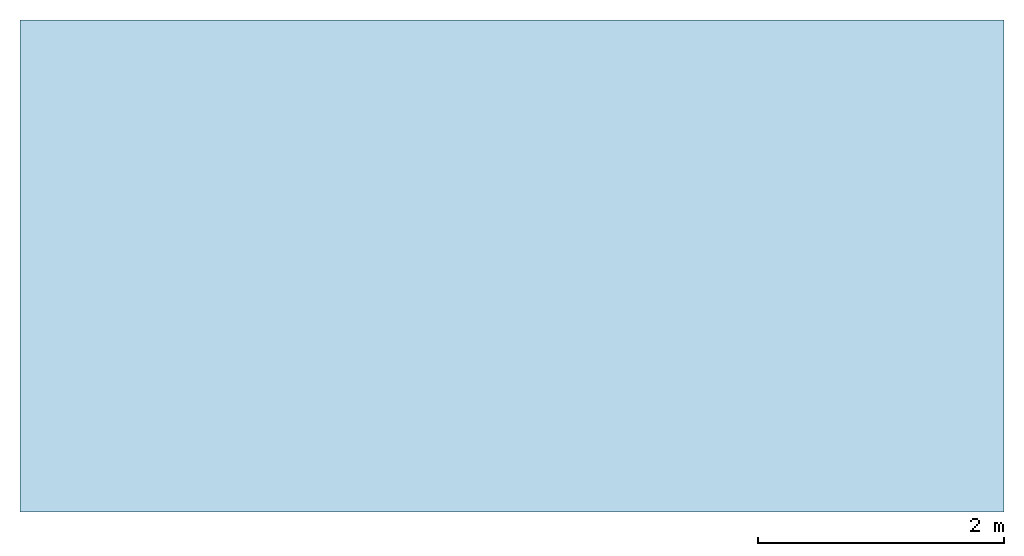
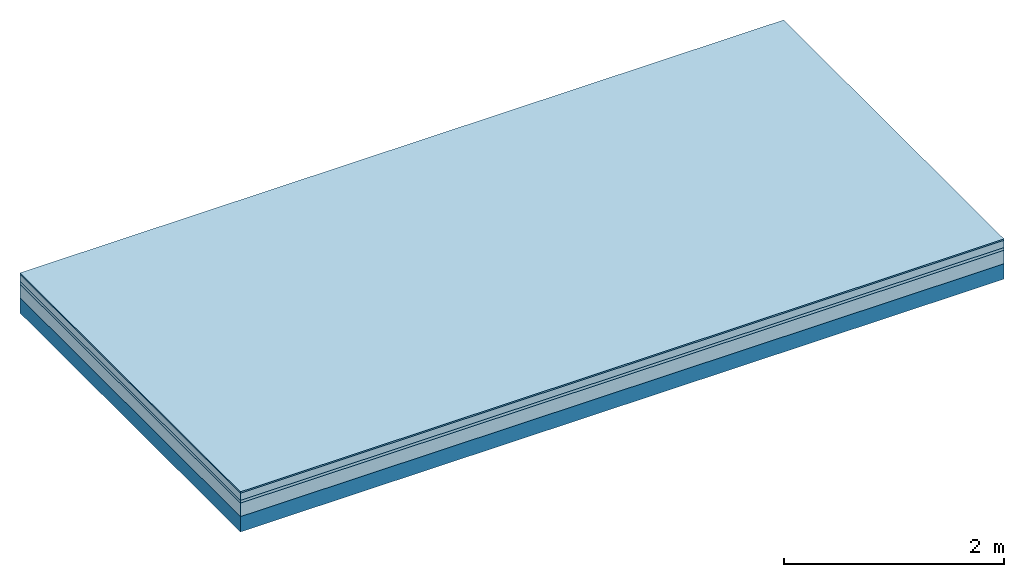
# One storey: 4 plates, 1 member, 1 element without a shape of its own.
"""IFC4 building model written with IfcOpenShell, lengths in metres."""

from ifc_helpers import new_model, si_unit, derived_unit, direction, frame, frame_2d, origin, origin_with_axes, place, context, project, spatial, rectangle, extrude, material, layer, layer_set, type_object, element, aggregate, save


model = new_model("IFC4")

# Units and contexts
plan_context = context("Plan", 3, precision=1e-05, world=origin(), true_north=direction((0.0, 1.0)))
model_context = context("Model", 3, precision=1e-05, world=origin(), true_north=direction((0.0, 1.0)))
ifc_project = project(units=[si_unit("LENGTHUNIT", "METRE"), derived_unit("SOUNDPRESSUREUNIT", [(si_unit("PRESSUREUNIT", "PASCAL", prefix="MICRO"), 0)]), si_unit("ENERGYUNIT", "JOULE", prefix="MEGA"), si_unit("MASSUNIT", "GRAM", prefix="KILO"), derived_unit("THERMALTRANSMITTANCEUNIT", [(si_unit("POWERUNIT", "WATT"), 1), (si_unit("AREAUNIT", "SQUARE_METRE"), -1), (si_unit("THERMODYNAMICTEMPERATUREUNIT", "KELVIN"), -1)]), derived_unit("AREADENSITYUNIT", [(si_unit("MASSUNIT", "GRAM", prefix="KILO"), 1), (si_unit("AREAUNIT", "SQUARE_METRE"), -1)]), derived_unit("USERDEFINED", [(si_unit("ENERGYUNIT", "JOULE", prefix="MEGA"), 1), (si_unit("AREAUNIT", "SQUARE_METRE"), -1)])], contexts=[plan_context, model_context])

# Site, building, storey
site = spatial("IfcSite", under=ifc_project)
building_placement = place(None, origin())
building = spatial("IfcBuilding", under=site, at=building_placement)
storey_placement = place(building_placement, origin())
storey = spatial("IfcBuildingStorey", under=building, at=storey_placement)

# Slab, member, plates
ifc_material_1 = material(Category="11.013")
ifc_layer_1 = layer(ifc_material_1, 0.015, Name="Flooring")
ifc_material_2 = material(Name="Cement screed", Category="04.006")
ifc_layer_2 = layer(ifc_material_2, 0.08, Name="On-material")
ifc_material_3 = material(Name="Wood fiber generic product", Category="10.009")
ifc_layer_3 = layer(ifc_material_3, 0.03, Name="Impact sound insulation")
ifc_material_4 = material(Category="01.002")
ifc_layer_4 = layer(ifc_material_4, 0.15, Name="Sub-floor")
ifc_material_5 = material(Name="Rigid, of the art")
ifc_layer_5 = layer(ifc_material_5, 0.0, Name="Bond")
ifc_layer_6 = layer(None, 0.17, Name="Supporting structure")
ifc_layer_set = layer_set([ifc_layer_1, ifc_layer_2, ifc_layer_3, ifc_layer_4, ifc_layer_5, ifc_layer_6])
slab_type = type_object("IfcSlabType", Name="A2194", PredefinedType="NOTDEFINED", material=ifc_layer_set)
slab_placement = place(None, frame((0.0, 0.0, 0.0), z_axis=(0.0, 0.0, -1.0), x_axis=(1.0, 0.0, 0.0)))
slab = element("IfcSlab", 1, at=slab_placement, inside=storey, type_object=slab_type, material=ifc_layer_set, Name="Slab #1")
ifc_material_6 = material(Name="Solid timber panel")
member_placement = place(slab_placement, origin())
member = element("IfcMember", 2, at=member_placement, material=ifc_material_6, Name="Supporting structure", context=plan_context, shape_type="SweptSolid", body=[
    extrude(rectangle(XDim=1.0, YDim=0.17, at=frame_2d((0.5, 0.085), x_axis=(1.0, 0.0))), frame((0.0, 4.0, 0.275), z_axis=(0.0, -1.0, 0.0), x_axis=(1.0, 0.0, 0.0)), (0.0, 0.0, 1.0), 4.0),
    extrude(rectangle(XDim=1.0, YDim=0.17, at=frame_2d((0.5, 0.085), x_axis=(1.0, 0.0))), frame((1.0, 4.0, 0.275), z_axis=(0.0, -1.0, 0.0), x_axis=(1.0, 0.0, 0.0)), (0.0, 0.0, 1.0), 4.0),
    extrude(rectangle(XDim=1.0, YDim=0.17, at=frame_2d((0.5, 0.085), x_axis=(1.0, 0.0))), frame((2.0, 4.0, 0.275), z_axis=(0.0, -1.0, 0.0), x_axis=(1.0, 0.0, 0.0)), (0.0, 0.0, 1.0), 4.0),
    extrude(rectangle(XDim=1.0, YDim=0.17, at=frame_2d((0.5, 0.085), x_axis=(1.0, 0.0))), frame((3.0, 4.0, 0.275), z_axis=(0.0, -1.0, 0.0), x_axis=(1.0, 0.0, 0.0)), (0.0, 0.0, 1.0), 4.0),
    extrude(rectangle(XDim=1.0, YDim=0.17, at=frame_2d((0.5, 0.085), x_axis=(1.0, 0.0))), frame((4.0, 4.0, 0.275), z_axis=(0.0, -1.0, 0.0), x_axis=(1.0, 0.0, 0.0)), (0.0, 0.0, 1.0), 4.0),
    extrude(rectangle(XDim=1.0, YDim=0.17, at=frame_2d((0.5, 0.085), x_axis=(1.0, 0.0))), frame((5.0, 4.0, 0.275), z_axis=(0.0, -1.0, 0.0), x_axis=(1.0, 0.0, 0.0)), (0.0, 0.0, 1.0), 4.0),
    extrude(rectangle(XDim=1.0, YDim=0.17, at=frame_2d((0.5, 0.085), x_axis=(1.0, 0.0))), frame((6.0, 4.0, 0.275), z_axis=(0.0, -1.0, 0.0), x_axis=(1.0, 0.0, 0.0)), (0.0, 0.0, 1.0), 4.0),
    extrude(rectangle(XDim=1.0, YDim=0.17, at=frame_2d((0.5, 0.085), x_axis=(1.0, 0.0))), frame((7.0, 4.0, 0.275), z_axis=(0.0, -1.0, 0.0), x_axis=(1.0, 0.0, 0.0)), (0.0, 0.0, 1.0), 4.0),
])
plate_1_placement = place(slab_placement, origin())
plate_1 = element("IfcPlate", 3, at=plate_1_placement, material=ifc_material_1, Name="Flooring", context=plan_context, shape_type="SweptSolid", body=[
    extrude(rectangle(XDim=8.0, YDim=4.0, at=frame_2d((4.0, 2.0), x_axis=(1.0, 0.0))), origin_with_axes(), (0.0, 0.0, 1.0), 0.015),
])
plate_2_placement = place(slab_placement, origin())
plate_2 = element("IfcPlate", 4, at=plate_2_placement, material=ifc_material_2, Name="On-material", context=plan_context, shape_type="SweptSolid", body=[
    extrude(rectangle(XDim=8.0, YDim=4.0, at=frame_2d((4.0, 2.0), x_axis=(1.0, 0.0))), frame((0.0, 0.0, 0.015), z_axis=(0.0, 0.0, 1.0), x_axis=(1.0, 0.0, 0.0)), (0.0, 0.0, 1.0), 0.08),
])
plate_3_placement = place(slab_placement, origin())
plate_3 = element("IfcPlate", 5, at=plate_3_placement, material=ifc_material_3, Name="Impact sound insulation", context=plan_context, shape_type="SweptSolid", body=[
    extrude(rectangle(XDim=8.0, YDim=4.0, at=frame_2d((4.0, 2.0), x_axis=(1.0, 0.0))), frame((0.0, 0.0, 0.095), z_axis=(0.0, 0.0, 1.0), x_axis=(1.0, 0.0, 0.0)), (0.0, 0.0, 1.0), 0.03),
])
plate_4_placement = place(slab_placement, origin())
plate_4 = element("IfcPlate", 6, at=plate_4_placement, material=ifc_material_4, Name="Sub-floor", context=plan_context, shape_type="SweptSolid", body=[
    extrude(rectangle(XDim=8.0, YDim=4.0, at=frame_2d((4.0, 2.0), x_axis=(1.0, 0.0))), frame((0.0, 0.0, 0.125), z_axis=(0.0, 0.0, 1.0), x_axis=(1.0, 0.0, 0.0)), (0.0, 0.0, 1.0), 0.15),
])
aggregate(slab, [plate_1, plate_2, plate_3, plate_4, member])

save(model, "model.ifc")
